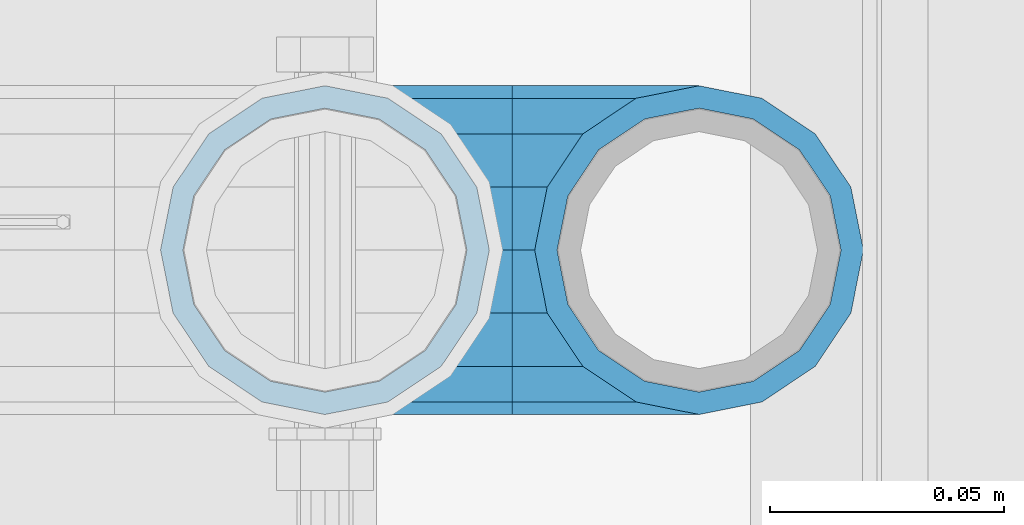
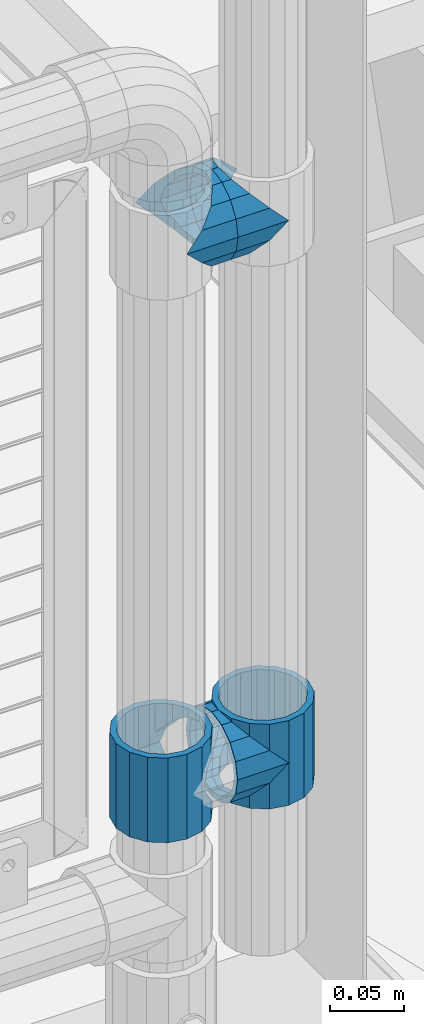
# One storey, part 187 of 270: 5 beams.
"""IFC2X3 building model written with IfcOpenShell, lengths in millimetres."""

from ifc_helpers import new_model, si_unit, frame, origin_with_axes, place, context, subcontext, project, spatial, faceted_brep, material, type_object, element, save


model = new_model("IFC2X3")

# Units and contexts
model_context = context("Model", 3, precision=1e-05, world=origin_with_axes())
body_context = subcontext(model_context, "Body", "Model", "MODEL_VIEW")
ifc_project = project(units=[si_unit("LENGTHUNIT", "METRE", prefix="MILLI"), si_unit("AREAUNIT", "SQUARE_METRE"), si_unit("VOLUMEUNIT", "CUBIC_METRE"), si_unit("MASSUNIT", "GRAM", prefix="KILO"), si_unit("TIMEUNIT", "SECOND"), si_unit("PLANEANGLEUNIT", "RADIAN"), si_unit("SOLIDANGLEUNIT", "STERADIAN"), si_unit("THERMODYNAMICTEMPERATUREUNIT", "DEGREE_CELSIUS"), si_unit("LUMINOUSINTENSITYUNIT", "LUMEN")], contexts=[model_context])

# Site, building, storey
site_placement = place(None, origin_with_axes())
site = spatial("IfcSite", under=ifc_project, at=site_placement, CompositionType="ELEMENT")
building_placement = place(site_placement, origin_with_axes())
building = spatial("IfcBuilding", under=site, at=building_placement, Name="Standard", CompositionType="ELEMENT")
storey_placement = place(building_placement, origin_with_axes())
storey = spatial("IfcBuildingStorey", under=building, at=storey_placement, Name="Undefined", CompositionType="ELEMENT", Elevation=0.0)

# Beams
ifc_material = material(Name="Misc_Undefined")
beam_type = type_object("IfcBeamType", PredefinedType="NOTDEFINED")
beam_1_placement = place(storey_placement, frame((19874.0, -16335.5, 398.670000000001), z_axis=(0.0, 1.0, 0.0), x_axis=(-1.0, 0.0, 0.0)))
element("IfcBeam", 1, at=beam_1_placement, inside=storey, type_object=beam_type, material=ifc_material, context=body_context, shape_type="Brep", body=[
    faceted_brep([(0.0, 0.0, -35.1499999999996), (13.4513226476338, -13.4513226476329, -32.4743655677721), (13.4513226476338, 13.4513226476329, -32.4743655677721), (32.4743655677703, -26.8123795176775, 13.4513226476338), (32.4743655677703, -32.4743655677717, 13.4513226476338), (24.8548033587067, -24.8548033587072, 24.8548033587067), (24.8548033587067, -16.3810424080045, 24.8548033587067), (27.1226768591041, -21.4606908090117, 21.4606908090118), (35.1500000000015, -30.35, 0.0), (35.1500000000015, -35.15, 0.0), (32.8397438117208, -28.0397438117175, 11.6144421722802), (32.8397438117172, -28.0397438117175, -11.6144421722802), (32.4743655677703, -26.8123795176776, -13.4513226476338), (32.4743655677703, -32.4743655677717, -13.4513226476338), (27.1226768591041, -21.4606908090117, -21.4606908090118), (24.8548033587067, -16.3810424080045, -24.8548033587067), (24.8548033587067, -24.8548033587072, -24.8548033587067), (20.0882031229849, -11.6144421722805, -28.0397438117179), (16.6306603983721, 0.0, -30.3500000000004), (20.0882031229849, 11.6144421722805, -28.0397438117179), (24.8548033587067, 16.3810424080045, -24.8548033587067), (24.8548033587067, 24.8548033587072, -24.8548033587067), (27.1226768591041, 21.4606908090117, -21.4606908090118), (32.4743655677703, 26.8123795176775, -13.4513226476338), (32.4743655677703, 32.4743655677717, -13.4513226476338), (32.8397438117172, 28.0397438117175, -11.6144421722802), (35.1500000000015, 30.35, 0.0), (35.1500000000015, 35.1500000000003, 0.0), (32.8397438117208, 28.0397438117175, 11.6144421722802), (32.4743655677703, 26.8123795176776, 13.4513226476338), (32.4743655677703, 32.4743655677717, 13.4513226476338), (27.1226768591041, 21.4606908090117, 21.4606908090118), (24.8548033587067, 16.3810424080045, 24.8548033587067), (24.8548033587067, 24.8548033587072, 24.8548033587067), (13.4513226476338, 13.4513226476329, 32.4743655677721), (13.4513226476338, -13.4513226476329, 32.4743655677721), (0.0, 0.0, 35.1499999999996), (20.0882031229812, 11.6144421722805, 28.0397438117179), (16.6306603983612, 0.0, 30.3500000000004), (20.0882031229812, -11.6144421722805, 28.0397438117179), (40.1500000000015, -35.15, 0.0), (40.1500000000015, -32.4743655677717, 13.4513226476338), (40.1500000000015, -24.8548033587072, 24.8548033587067), (40.1500000000015, -13.4513226476329, 32.4743655677721), (40.1500000000015, 0.0, 35.1499999999996), (40.1500000000015, -24.8548033587072, -24.8548033587067), (40.1500000000015, -32.4743655677717, -13.4513226476338), (40.1500000000015, -13.4513226476329, -32.4743655677721), (40.1500000000015, 0.0, -35.1499999999996), (40.1500000000015, 13.4513226476329, -32.4743655677721), (40.1500000000015, 24.8548033587072, -24.8548033587067), (40.1500000000015, 32.4743655677717, -13.4513226476338), (40.1500000000015, 35.15, 0.0), (40.1500000000015, 32.4743655677717, 13.4513226476338), (40.1500000000015, 24.8548033587072, 24.8548033587067), (40.1500000000015, 13.4513226476329, 32.4743655677721), (40.1500000000015, -21.4606908090117, 21.4606908090118), (40.1500000000015, -11.6144421722805, 28.0397438117179), (40.1500000000015, 0.0, 30.3500000000004), (40.1500000000015, 11.6144421722805, 28.0397438117179), (40.1500000000015, 21.4606908090117, 21.4606908090118), (40.1500000000015, 28.0397438117175, 11.6144421722802), (40.1500000000015, 30.35, 0.0), (40.1500000000015, 28.0397438117175, -11.6144421722802), (40.1500000000015, 21.4606908090117, -21.4606908090118), (40.1500000000015, 11.6144421722805, -28.0397438117179), (40.1500000000015, 0.0, -30.3500000000004), (40.1500000000015, -11.6144421722805, -28.0397438117179), (40.1500000000015, -21.4606908090117, -21.4606908090118), (40.1500000000015, -28.0397438117175, -11.6144421722802), (40.1500000000015, -30.35, 0.0), (40.1500000000015, -28.0397438117175, 11.6144421722802)], [[[0, 1, 2]], [[3, 4, 5, 6, 7]], [[8, 9, 4, 3, 10]], [[11, 12, 13, 9, 8]], [[14, 15, 16, 13, 12]], [[2, 1, 16, 15, 17, 18, 19, 20, 21]], [[21, 20, 22, 23, 24]], [[24, 23, 25, 26, 27]], [[27, 26, 28, 29, 30]], [[30, 29, 31, 32, 33]], [[34, 35, 36]], [[33, 32, 37, 38, 39, 6, 5, 35, 34]], [[40, 41, 4, 9]], [[41, 42, 5, 4]], [[42, 43, 35, 5]], [[43, 44, 36, 35]], [[45, 46, 13, 16]], [[47, 45, 16, 1]], [[48, 47, 1, 0]], [[49, 48, 0, 2]], [[50, 49, 2, 21]], [[51, 50, 21, 24]], [[52, 51, 24, 27]], [[53, 52, 27, 30]], [[54, 53, 30, 33]], [[55, 54, 33, 34]], [[44, 55, 34, 36]], [[46, 40, 9, 13]], [[45, 47, 48, 49, 50, 51, 52, 53, 54, 55, 44, 43, 42, 41, 40, 46], [56, 57, 58, 59, 60, 61, 62, 63, 64, 65, 66, 67, 68, 69, 70, 71]], [[59, 58, 38, 37]], [[60, 59, 37, 32, 31]], [[61, 60, 31, 29, 28]], [[62, 61, 28, 26]], [[63, 62, 26, 25]], [[22, 64, 63, 25, 23]], [[19, 65, 64, 22, 20]], [[66, 65, 19, 18]], [[67, 66, 18, 17]], [[68, 67, 17, 15, 14]], [[69, 68, 14, 12, 11]], [[70, 69, 11, 8]], [[71, 70, 8, 10]], [[7, 56, 71, 10, 3]], [[39, 57, 56, 7, 6]], [[58, 57, 39, 38]]]),
])
beam_2_placement = place(storey_placement, frame((19794.0, -16335.5, 433.82), z_axis=(-1.0, 0.0, 0.0), x_axis=(0.0, 0.0, -1.0)))
element("IfcBeam", 2, at=beam_2_placement, inside=storey, type_object=beam_type, material=ifc_material, context=body_context, shape_type="Brep", body=[
    faceted_brep([(7.11025618828319, -11.6144421722802, -32.8397438117172), (7.11025618828319, -11.6144421722802, -28.0397438117179), (13.689309190989, -21.4606908090118, -21.46069080901), (13.689309190989, -21.4606908090118, -27.1226768591041), (8.33762048232484, -13.4513226476338, -32.4743655677703), (23.5355578277203, -28.0397438117179, -11.614442172282), (23.5355578277203, -28.0397438117179, -20.0882031229885), (18.7689575919954, -24.8548033587067, -24.8548033587067), (35.1500000000015, -30.35, 0.0), (35.1500000000008, -30.3500000000004, -16.6306603983721), (46.7644421722812, -28.0397438117179, -11.614442172282), (46.7644421722812, -28.0397438117179, -20.0882031229885), (51.5310424080071, -24.8548033587067, -24.8548033587067), (56.6106908090125, -21.4606908090118, -21.46069080901), (56.6106908090125, -21.4606908090118, -27.1226768591041), (61.9623795176767, -13.4513226476338, -32.4743655677703), (63.1897438117183, -11.6144421722802, -28.0397438117179), (63.1897438117183, -11.6144421722802, -32.8397438117172), (65.5000000000008, 0.0, -30.3499999999985), (65.5000000000008, 0.0, -35.1500000000015), (63.1897438117183, 11.6144421722802, -28.0397438117179), (63.1897438117183, 11.6144421722802, -32.8397438117208), (56.6106908090125, 21.4606908090118, -21.46069080901), (56.6106908090125, 21.4606908090118, -27.1226768591005), (61.9623795176767, 13.4513226476338, -32.4743655677703), (46.7644421722812, 28.0397438117179, -11.614442172282), (46.7644421722812, 28.0397438117179, -20.0882031229812), (51.5310424080071, 24.8548033587067, -24.8548033587067), (35.1500000000015, 30.35, 0.0), (35.1500000000008, 30.3500000000004, -16.6306603983612), (23.5355578277203, 28.0397438117179, -11.614442172282), (23.5355578277203, 28.0397438117179, -20.0882031229812), (18.7689575919954, 24.8548033587067, -24.8548033587067), (13.689309190989, 21.4606908090118, -21.46069080901), (13.689309190989, 21.4606908090118, -27.1226768591005), (8.33762048232484, 13.4513226476338, -32.4743655677703), (7.11025618828324, 11.6144421722802, -28.0397438117179), (7.11025618828324, 11.6144421722802, -32.8397438117208), (4.80000000000075, 0.0, -30.3499999999985), (4.80000000000075, 0.0, -35.1500000000015), (0.0, 21.4606908090118, 21.46069080901), (0.0, 28.0397438117179, 11.614442172282), (70.2999999999993, 28.0397438117179, 11.614442172282), (70.2999999999993, 21.4606908090118, 21.46069080901), (0.0, 11.6144421722802, 28.0397438117179), (70.2999999999993, 11.6144421722802, 28.0397438117179), (0.0, 0.0, 30.3499999999985), (70.2999999999993, 0.0, 30.3499999999985), (0.0, -11.6144421722802, 28.0397438117179), (70.2999999999993, -11.6144421722802, 28.0397438117179), (0.0, -21.4606908090118, 21.46069080901), (70.2999999999993, -21.4606908090118, 21.46069080901), (0.0, -28.0397438117179, 11.614442172282), (70.2999999999993, -28.0397438117179, 11.614442172282), (0.0, -24.8548033587067, -24.8548033587067), (0.0, -13.4513226476338, -32.4743655677703), (0.0, 0.0, -35.1499999999996), (0.0, -32.4743655677721, 13.4513226476338), (0.0, -35.1499999999996, 0.0), (70.2999999999993, -35.1499999999996, 0.0), (70.2999999999993, -32.4743655677721, 13.4513226476338), (0.0, -24.8548033587067, 24.8548033587067), (70.2999999999993, -24.8548033587067, 24.8548033587067), (0.0, -13.4513226476338, 32.4743655677703), (70.2999999999993, -13.4513226476338, 32.4743655677703), (0.0, 0.0, 35.1499999999996), (70.2999999999993, 0.0, 35.1500000000015), (0.0, 13.4513226476338, 32.4743655677703), (70.2999999999993, 13.4513226476338, 32.4743655677703), (0.0, 24.8548033587067, 24.8548033587067), (70.2999999999993, 24.8548033587067, 24.8548033587067), (0.0, 32.4743655677721, 13.4513226476338), (70.2999999999993, 32.4743655677721, 13.4513226476338), (0.0, 35.1499999999996, 0.0), (70.2999999999993, 35.1499999999996, 0.0), (0.0, 32.4743655677721, -13.4513226476338), (70.2999999999993, 32.4743655677721, -13.4513226476338), (70.2999999999993, -13.4513226476338, -32.4743655677703), (70.2999999999993, -24.8548033587067, -24.8548033587067), (70.2999999999993, 0.0, -35.1500000000015), (70.2999999999993, 13.4513226476338, -32.4743655677703), (70.2999999999993, 24.8548033587067, -24.8548033587067), (0.0, 24.8548033587067, -24.8548033587067), (0.0, 13.4513226476338, -32.4743655677703), (70.2999999999993, -32.4743655677721, -13.4513226476338), (0.0, -32.4743655677721, -13.4513226476338), (0.0, -28.0397438117179, -11.614442172282), (0.0, -21.4606908090118, -21.46069080901), (0.0, -11.6144421722802, -28.0397438117179), (0.0, 0.0, -30.3499999999985), (0.0, 11.6144421722802, -28.0397438117179), (0.0, 21.4606908090118, -21.46069080901), (0.0, 28.0397438117179, -11.614442172282), (0.0, 30.3500000000004, 0.0), (0.0, -30.3500000000004, 0.0), (70.2999999999993, 30.3500000000004, 0.0), (70.2999999999993, 28.0397438117179, -11.614442172282), (70.2999999999993, 21.4606908090118, -21.46069080901), (70.2999999999993, 11.6144421722802, -28.0397438117179), (70.2999999999993, 0.0, -30.3499999999985), (70.2999999999993, -11.6144421722802, -28.0397438117179), (70.2999999999993, -21.4606908090118, -21.46069080901), (70.2999999999993, -28.0397438117179, -11.614442172282), (70.2999999999993, -30.3500000000004, 0.0)], [[[0, 1, 2, 3, 4]], [[3, 2, 5, 6, 7]], [[6, 5, 8, 9]], [[9, 8, 10, 11]], [[12, 11, 10, 13, 14]], [[15, 14, 13, 16, 17]], [[17, 16, 18, 19]], [[19, 18, 20, 21]], [[21, 20, 22, 23, 24]], [[23, 22, 25, 26, 27]], [[26, 25, 28, 29]], [[29, 28, 30, 31]], [[32, 31, 30, 33, 34]], [[35, 34, 33, 36, 37]], [[37, 36, 38, 39]], [[39, 38, 1, 0]], [[40, 41, 42, 43]], [[44, 40, 43, 45]], [[46, 44, 45, 47]], [[48, 46, 47, 49]], [[50, 48, 49, 51]], [[52, 50, 51, 53]], [[7, 54, 55, 4, 3]], [[4, 55, 56, 39, 0]], [[57, 58, 59, 60]], [[61, 57, 60, 62]], [[63, 61, 62, 64]], [[65, 63, 64, 66]], [[67, 65, 66, 68]], [[69, 67, 68, 70]], [[71, 69, 70, 72]], [[73, 71, 72, 74]], [[75, 73, 74, 76]], [[77, 78, 12, 14, 15]], [[79, 77, 15, 17, 19]], [[24, 80, 79, 19, 21]], [[27, 81, 80, 24, 23]], [[82, 75, 76, 81, 27, 26, 29, 31, 32]], [[83, 82, 32, 34, 35]], [[56, 83, 35, 37, 39]], [[9, 11, 12, 78, 84, 85, 54, 7, 6]], [[58, 85, 84, 59]], [[57, 61, 63, 65, 67, 69, 71, 73, 75, 82, 83, 56, 55, 54, 85, 58], [86, 87, 88, 89, 90, 91, 92, 93, 41, 40, 44, 46, 48, 50, 52, 94]], [[90, 89, 38, 36]], [[91, 90, 36, 33]], [[92, 91, 33, 30]], [[93, 92, 30, 28]], [[41, 93, 28, 95, 42]], [[96, 95, 28, 25]], [[97, 96, 25, 22]], [[98, 97, 22, 20]], [[99, 98, 20, 18]], [[100, 99, 18, 16]], [[101, 100, 16, 13]], [[102, 101, 13, 10]], [[103, 102, 10, 8]], [[78, 77, 79, 80, 81, 76, 74, 72, 70, 68, 66, 64, 62, 60, 59, 84], [51, 49, 47, 45, 43, 42, 95, 96, 97, 98, 99, 100, 101, 102, 103, 53]], [[8, 94, 52, 53, 103]], [[86, 94, 8, 5]], [[87, 86, 5, 2]], [[88, 87, 2, 1]], [[89, 88, 1, 38]]]),
])
beam_3_placement = place(storey_placement, frame((19874.0, -16335.5, 433.82), z_axis=(1.0, 0.0, 0.0), x_axis=(0.0, 0.0, -1.0)))
element("IfcBeam", 3, at=beam_3_placement, inside=storey, type_object=beam_type, material=ifc_material, context=body_context, shape_type="Brep", body=[
    faceted_brep([(56.6106908090125, 21.4606908090118, -27.1226768591005), (56.6106908090125, 21.4606908090118, -21.46069080901), (46.7644421722812, 28.0397438117179, -11.614442172282), (46.7644421722812, 28.0397438117179, -20.0882031229812), (51.5310424080071, 24.8548033587067, -24.8548033587067), (63.1897438117183, 11.6144421722802, -32.8397438117208), (63.1897438117183, 11.6144421722802, -28.0397438117179), (61.9623795176767, 13.4513226476338, -32.4743655677703), (65.5000000000008, 0.0, -35.1500000000015), (65.5000000000008, 0.0, -30.3499999999985), (63.1897438117183, -11.6144421722802, -32.8397438117172), (63.1897438117183, -11.6144421722802, -28.0397438117179), (61.9623795176767, -13.4513226476338, -32.4743655677703), (56.6106908090125, -21.4606908090118, -27.1226768591041), (56.6106908090125, -21.4606908090118, -21.46069080901), (51.5310424080071, -24.8548033587067, -24.8548033587067), (46.7644421722812, -28.0397438117179, -20.0882031229885), (46.7644421722812, -28.0397438117179, -11.614442172282), (35.1500000000008, -30.3500000000004, -16.6306603983721), (35.1500000000015, -30.35, 0.0), (23.5355578277203, -28.0397438117179, -20.0882031229885), (23.5355578277203, -28.0397438117179, -11.614442172282), (13.689309190989, -21.4606908090118, -27.1226768591041), (13.689309190989, -21.4606908090118, -21.46069080901), (18.7689575919954, -24.8548033587067, -24.8548033587067), (7.11025618828319, -11.6144421722802, -32.8397438117172), (7.11025618828319, -11.6144421722802, -28.0397438117179), (8.33762048232484, -13.4513226476338, -32.4743655677703), (4.80000000000075, 0.0, -35.1500000000015), (4.80000000000075, 0.0, -30.3499999999985), (7.11025618828324, 11.6144421722802, -32.8397438117208), (7.11025618828324, 11.6144421722802, -28.0397438117179), (8.33762048232484, 13.4513226476338, -32.4743655677703), (13.689309190989, 21.4606908090118, -27.1226768591005), (13.689309190989, 21.4606908090118, -21.46069080901), (18.7689575919954, 24.8548033587067, -24.8548033587067), (23.5355578277203, 28.0397438117179, -20.0882031229812), (23.5355578277203, 28.0397438117179, -11.614442172282), (35.1500000000008, 30.3500000000004, -16.6306603983612), (35.1500000000015, 30.35, 0.0), (0.0, 32.4743655677721, -13.4513226476338), (0.0, 35.1499999999996, 0.0), (70.2999999999993, 35.1499999999996, 0.0), (70.2999999999993, 32.4743655677721, -13.4513226476338), (0.0, 32.4743655677721, 13.4513226476338), (70.2999999999993, 32.4743655677721, 13.4513226476338), (0.0, 24.8548033587067, 24.8548033587067), (70.2999999999993, 24.8548033587067, 24.8548033587067), (0.0, 13.4513226476338, 32.4743655677703), (70.2999999999993, 13.4513226476338, 32.4743655677703), (0.0, 0.0, 35.1499999999996), (70.2999999999993, 0.0, 35.1500000000015), (0.0, -13.4513226476338, 32.4743655677703), (70.2999999999993, -13.4513226476338, 32.4743655677703), (0.0, -24.8548033587067, 24.8548033587067), (70.2999999999993, -24.8548033587067, 24.8548033587067), (0.0, -32.4743655677721, 13.4513226476338), (70.2999999999993, -32.4743655677721, 13.4513226476338), (0.0, -35.1499999999996, 0.0), (70.2999999999993, -35.1499999999996, 0.0), (70.2999999999993, -30.3500000000004, 0.0), (70.2999999999993, -28.0397438117179, -11.614442172282), (70.2999999999993, -21.4606908090118, -21.46069080901), (70.2999999999993, -11.6144421722802, -28.0397438117179), (70.2999999999993, 0.0, -30.3499999999985), (70.2999999999993, 11.6144421722802, -28.0397438117179), (70.2999999999993, 21.4606908090118, -21.46069080901), (70.2999999999993, 28.0397438117179, -11.614442172282), (0.0, -28.0397438117179, -11.614442172282), (0.0, -30.3500000000004, 0.0), (0.0, -21.4606908090118, -21.46069080901), (0.0, -11.6144421722802, -28.0397438117179), (0.0, 0.0, -30.3499999999985), (0.0, 11.6144421722802, -28.0397438117179), (0.0, 21.4606908090118, -21.46069080901), (0.0, 28.0397438117179, -11.614442172282), (0.0, 30.3500000000004, 0.0), (70.2999999999993, 30.3500000000004, 0.0), (0.0, 28.0397438117179, 11.614442172282), (70.2999999999993, 28.0397438117179, 11.614442172282), (0.0, 21.4606908090118, 21.46069080901), (70.2999999999993, 21.4606908090118, 21.46069080901), (0.0, 11.6144421722802, 28.0397438117179), (70.2999999999993, 11.6144421722802, 28.0397438117179), (0.0, 0.0, 30.3499999999985), (70.2999999999993, 0.0, 30.3499999999985), (0.0, -11.6144421722802, 28.0397438117179), (70.2999999999993, -11.6144421722802, 28.0397438117179), (0.0, -21.4606908090118, 21.46069080901), (70.2999999999993, -21.4606908090118, 21.46069080901), (0.0, -28.0397438117179, 11.614442172282), (70.2999999999993, -28.0397438117179, 11.614442172282), (70.2999999999993, -24.8548033587067, -24.8548033587067), (70.2999999999993, -13.4513226476338, -32.4743655677703), (70.2999999999993, 0.0, -35.1500000000015), (70.2999999999993, 13.4513226476338, -32.4743655677703), (70.2999999999993, 24.8548033587067, -24.8548033587067), (70.2999999999993, -32.4743655677721, -13.4513226476338), (0.0, -32.4743655677721, -13.4513226476338), (0.0, 24.8548033587067, -24.8548033587067), (0.0, 13.4513226476338, -32.4743655677703), (0.0, 0.0, -35.1499999999996), (0.0, -13.4513226476338, -32.4743655677703), (0.0, -24.8548033587067, -24.8548033587067)], [[[0, 1, 2, 3, 4]], [[5, 6, 1, 0, 7]], [[8, 9, 6, 5]], [[10, 11, 9, 8]], [[12, 13, 14, 11, 10]], [[15, 16, 17, 14, 13]], [[18, 19, 17, 16]], [[20, 21, 19, 18]], [[22, 23, 21, 20, 24]], [[25, 26, 23, 22, 27]], [[28, 29, 26, 25]], [[30, 31, 29, 28]], [[32, 33, 34, 31, 30]], [[35, 36, 37, 34, 33]], [[38, 39, 37, 36]], [[3, 2, 39, 38]], [[40, 41, 42, 43]], [[41, 44, 45, 42]], [[44, 46, 47, 45]], [[46, 48, 49, 47]], [[48, 50, 51, 49]], [[50, 52, 53, 51]], [[52, 54, 55, 53]], [[54, 56, 57, 55]], [[56, 58, 59, 57]], [[60, 61, 17, 19]], [[61, 62, 14, 17]], [[62, 63, 11, 14]], [[63, 64, 9, 11]], [[64, 65, 6, 9]], [[65, 66, 1, 6]], [[66, 67, 2, 1]], [[68, 69, 19, 21]], [[70, 68, 21, 23]], [[71, 70, 23, 26]], [[72, 71, 26, 29]], [[73, 72, 29, 31]], [[74, 73, 31, 34]], [[75, 74, 34, 37]], [[76, 75, 37, 39]], [[67, 77, 39, 2]], [[78, 76, 39, 77, 79]], [[80, 78, 79, 81]], [[82, 80, 81, 83]], [[84, 82, 83, 85]], [[86, 84, 85, 87]], [[88, 86, 87, 89]], [[90, 88, 89, 91]], [[19, 69, 90, 91, 60]], [[92, 93, 94, 95, 96, 43, 42, 45, 47, 49, 51, 53, 55, 57, 59, 97], [89, 87, 85, 83, 81, 79, 77, 67, 66, 65, 64, 63, 62, 61, 60, 91]], [[58, 98, 97, 59]], [[56, 54, 52, 50, 48, 46, 44, 41, 40, 99, 100, 101, 102, 103, 98, 58], [68, 70, 71, 72, 73, 74, 75, 76, 78, 80, 82, 84, 86, 88, 90, 69]], [[100, 99, 35, 33, 32]], [[101, 100, 32, 30, 28]], [[27, 102, 101, 28, 25]], [[24, 103, 102, 27, 22]], [[18, 16, 15, 92, 97, 98, 103, 24, 20]], [[93, 92, 15, 13, 12]], [[94, 93, 12, 10, 8]], [[7, 95, 94, 8, 5]], [[4, 96, 95, 7, 0]], [[99, 40, 43, 96, 4, 3, 38, 36, 35]]]),
])
beam_4_placement = place(storey_placement, frame((19794.0, -16335.5, 848.670000000001), z_axis=(0.0, -1.0, 0.0), x_axis=(1.0, 0.0, 0.0)))
element("IfcBeam", 4, at=beam_4_placement, inside=storey, type_object=beam_type, material=ifc_material, context=body_context, shape_type="Brep", body=[
    faceted_brep([(0.0, 0.0, -35.1499999999996), (13.4513226476338, -13.4513226476329, -32.4743655677721), (13.4513226476338, 13.4513226476329, -32.4743655677721), (32.4743655677703, 32.4743655677717, 13.4513226476338), (32.4743655677703, 26.8123795176776, 13.4513226476338), (27.1226768591041, 21.4606908090117, 21.4606908090118), (24.8548033587067, 16.3810424080045, 24.8548033587067), (24.8548033587067, 24.8548033587072, 24.8548033587067), (13.4513226476338, 13.4513226476329, 32.4743655677721), (13.4513226476338, -13.4513226476329, 32.4743655677721), (0.0, 0.0, 35.1499999999996), (20.0882031229812, 11.6144421722805, 28.0397438117179), (16.6306603983612, 0.0, 30.3500000000004), (20.0882031229812, -11.6144421722805, 28.0397438117179), (24.8548033587067, -16.3810424080045, 24.8548033587067), (24.8548033587067, -24.8548033587072, 24.8548033587067), (32.4743655677703, -26.8123795176775, 13.4513226476338), (32.4743655677703, -32.4743655677717, 13.4513226476338), (27.1226768591041, -21.4606908090117, 21.4606908090118), (35.1500000000015, -30.35, 0.0), (35.1500000000015, -35.15, 0.0), (32.8397438117208, -28.0397438117175, 11.6144421722802), (32.8397438117172, -28.0397438117175, -11.6144421722802), (32.4743655677703, -26.8123795176776, -13.4513226476338), (32.4743655677703, -32.4743655677717, -13.4513226476338), (27.1226768591041, -21.4606908090117, -21.4606908090118), (24.8548033587067, -16.3810424080045, -24.8548033587067), (24.8548033587067, -24.8548033587072, -24.8548033587067), (20.0882031229849, -11.6144421722805, -28.0397438117179), (16.6306603983721, 0.0, -30.3500000000004), (20.0882031229849, 11.6144421722805, -28.0397438117179), (24.8548033587067, 16.3810424080045, -24.8548033587067), (24.8548033587067, 24.8548033587072, -24.8548033587067), (27.1226768591041, 21.4606908090117, -21.4606908090118), (32.4743655677703, 26.8123795176775, -13.4513226476338), (32.4743655677703, 32.4743655677717, -13.4513226476338), (32.8397438117172, 28.0397438117175, -11.6144421722802), (35.1500000000015, 30.35, 0.0), (35.1500000000015, 35.1500000000003, 0.0), (32.8397438117208, 28.0397438117175, 11.6144421722802), (40.1500000000015, -35.15, 0.0), (40.1500000000015, -32.4743655677717, 13.4513226476338), (40.1500000000015, -24.8548033587072, 24.8548033587067), (40.1500000000015, -13.4513226476329, 32.4743655677721), (40.1500000000015, 0.0, 35.1499999999996), (40.1500000000015, 13.4513226476329, 32.4743655677721), (40.1500000000015, 24.8548033587072, 24.8548033587067), (40.1500000000015, 32.4743655677717, 13.4513226476338), (40.1500000000015, 35.15, 0.0), (40.1500000000015, -24.8548033587072, -24.8548033587067), (40.1500000000015, -32.4743655677717, -13.4513226476338), (40.1500000000015, -13.4513226476329, -32.4743655677721), (40.1500000000015, 0.0, -35.1499999999996), (40.1500000000015, 13.4513226476329, -32.4743655677721), (40.1500000000015, 24.8548033587072, -24.8548033587067), (40.1500000000015, 32.4743655677717, -13.4513226476338), (40.1500000000015, -21.4606908090117, 21.4606908090118), (40.1500000000015, -11.6144421722805, 28.0397438117179), (40.1500000000015, 0.0, 30.3500000000004), (40.1500000000015, 11.6144421722805, 28.0397438117179), (40.1500000000015, 21.4606908090117, 21.4606908090118), (40.1500000000015, 28.0397438117175, 11.6144421722802), (40.1500000000015, 30.35, 0.0), (40.1500000000015, 28.0397438117175, -11.6144421722802), (40.1500000000015, 21.4606908090117, -21.4606908090118), (40.1500000000015, 11.6144421722805, -28.0397438117179), (40.1500000000015, 0.0, -30.3500000000004), (40.1500000000015, -11.6144421722805, -28.0397438117179), (40.1500000000015, -21.4606908090117, -21.4606908090118), (40.1500000000015, -28.0397438117175, -11.6144421722802), (40.1500000000015, -30.35, 0.0), (40.1500000000015, -28.0397438117175, 11.6144421722802)], [[[0, 1, 2]], [[3, 4, 5, 6, 7]], [[8, 9, 10]], [[7, 6, 11, 12, 13, 14, 15, 9, 8]], [[16, 17, 15, 14, 18]], [[19, 20, 17, 16, 21]], [[22, 23, 24, 20, 19]], [[25, 26, 27, 24, 23]], [[2, 1, 27, 26, 28, 29, 30, 31, 32]], [[32, 31, 33, 34, 35]], [[35, 34, 36, 37, 38]], [[38, 37, 39, 4, 3]], [[40, 41, 17, 20]], [[41, 42, 15, 17]], [[42, 43, 9, 15]], [[43, 44, 10, 9]], [[44, 45, 8, 10]], [[45, 46, 7, 8]], [[46, 47, 3, 7]], [[47, 48, 38, 3]], [[49, 50, 24, 27]], [[51, 49, 27, 1]], [[52, 51, 1, 0]], [[53, 52, 0, 2]], [[54, 53, 2, 32]], [[55, 54, 32, 35]], [[48, 55, 35, 38]], [[50, 40, 20, 24]], [[49, 51, 52, 53, 54, 55, 48, 47, 46, 45, 44, 43, 42, 41, 40, 50], [56, 57, 58, 59, 60, 61, 62, 63, 64, 65, 66, 67, 68, 69, 70, 71]], [[63, 62, 37, 36]], [[33, 64, 63, 36, 34]], [[30, 65, 64, 33, 31]], [[66, 65, 30, 29]], [[67, 66, 29, 28]], [[68, 67, 28, 26, 25]], [[69, 68, 25, 23, 22]], [[70, 69, 22, 19]], [[71, 70, 19, 21]], [[18, 56, 71, 21, 16]], [[13, 57, 56, 18, 14]], [[58, 57, 13, 12]], [[59, 58, 12, 11]], [[60, 59, 11, 6, 5]], [[61, 60, 5, 4, 39]], [[62, 61, 39, 37]]]),
])
beam_5_placement = place(storey_placement, frame((19874.0, -16335.5, 848.670000000001), z_axis=(0.0, 1.0, 0.0), x_axis=(-1.0, 0.0, 0.0)))
element("IfcBeam", 5, at=beam_5_placement, inside=storey, type_object=beam_type, material=ifc_material, context=body_context, shape_type="Brep", body=[
    faceted_brep([(0.0, 0.0, -35.1499999999996), (13.4513226476338, -13.4513226476329, -32.4743655677721), (13.4513226476338, 13.4513226476329, -32.4743655677721), (32.4743655677703, -26.8123795176775, 13.4513226476338), (32.4743655677703, -32.4743655677717, 13.4513226476338), (24.8548033587067, -24.8548033587072, 24.8548033587067), (24.8548033587067, -16.3810424080045, 24.8548033587067), (27.1226768591041, -21.4606908090117, 21.4606908090118), (35.1500000000015, -30.35, 0.0), (35.1500000000015, -35.15, 0.0), (32.8397438117208, -28.0397438117175, 11.6144421722802), (32.8397438117172, -28.0397438117175, -11.6144421722802), (32.4743655677703, -26.8123795176776, -13.4513226476338), (32.4743655677703, -32.4743655677717, -13.4513226476338), (27.1226768591041, -21.4606908090117, -21.4606908090118), (24.8548033587067, -16.3810424080045, -24.8548033587067), (24.8548033587067, -24.8548033587072, -24.8548033587067), (20.0882031229849, -11.6144421722805, -28.0397438117179), (16.6306603983721, 0.0, -30.3500000000004), (20.0882031229849, 11.6144421722805, -28.0397438117179), (24.8548033587067, 16.3810424080045, -24.8548033587067), (24.8548033587067, 24.8548033587072, -24.8548033587067), (27.1226768591041, 21.4606908090117, -21.4606908090118), (32.4743655677703, 26.8123795176775, -13.4513226476338), (32.4743655677703, 32.4743655677717, -13.4513226476338), (32.8397438117172, 28.0397438117175, -11.6144421722802), (35.1500000000015, 30.35, 0.0), (35.1500000000015, 35.1500000000003, 0.0), (32.8397438117208, 28.0397438117175, 11.6144421722802), (32.4743655677703, 26.8123795176776, 13.4513226476338), (32.4743655677703, 32.4743655677717, 13.4513226476338), (27.1226768591041, 21.4606908090117, 21.4606908090118), (24.8548033587067, 16.3810424080045, 24.8548033587067), (24.8548033587067, 24.8548033587072, 24.8548033587067), (13.4513226476338, 13.4513226476329, 32.4743655677721), (13.4513226476338, -13.4513226476329, 32.4743655677721), (0.0, 0.0, 35.1499999999996), (20.0882031229812, 11.6144421722805, 28.0397438117179), (16.6306603983612, 0.0, 30.3500000000004), (20.0882031229812, -11.6144421722805, 28.0397438117179), (40.1500000000015, -35.15, 0.0), (40.1500000000015, -32.4743655677717, 13.4513226476338), (40.1500000000015, -24.8548033587072, 24.8548033587067), (40.1500000000015, -13.4513226476329, 32.4743655677721), (40.1500000000015, 0.0, 35.1499999999996), (40.1500000000015, -24.8548033587072, -24.8548033587067), (40.1500000000015, -32.4743655677717, -13.4513226476338), (40.1500000000015, -13.4513226476329, -32.4743655677721), (40.1500000000015, 0.0, -35.1499999999996), (40.1500000000015, 13.4513226476329, -32.4743655677721), (40.1500000000015, 24.8548033587072, -24.8548033587067), (40.1500000000015, 32.4743655677717, -13.4513226476338), (40.1500000000015, 35.15, 0.0), (40.1500000000015, 32.4743655677717, 13.4513226476338), (40.1500000000015, 24.8548033587072, 24.8548033587067), (40.1500000000015, 13.4513226476329, 32.4743655677721), (40.1500000000015, -21.4606908090117, 21.4606908090118), (40.1500000000015, -11.6144421722805, 28.0397438117179), (40.1500000000015, 0.0, 30.3500000000004), (40.1500000000015, 11.6144421722805, 28.0397438117179), (40.1500000000015, 21.4606908090117, 21.4606908090118), (40.1500000000015, 28.0397438117175, 11.6144421722802), (40.1500000000015, 30.35, 0.0), (40.1500000000015, 28.0397438117175, -11.6144421722802), (40.1500000000015, 21.4606908090117, -21.4606908090118), (40.1500000000015, 11.6144421722805, -28.0397438117179), (40.1500000000015, 0.0, -30.3500000000004), (40.1500000000015, -11.6144421722805, -28.0397438117179), (40.1500000000015, -21.4606908090117, -21.4606908090118), (40.1500000000015, -28.0397438117175, -11.6144421722802), (40.1500000000015, -30.35, 0.0), (40.1500000000015, -28.0397438117175, 11.6144421722802)], [[[0, 1, 2]], [[3, 4, 5, 6, 7]], [[8, 9, 4, 3, 10]], [[11, 12, 13, 9, 8]], [[14, 15, 16, 13, 12]], [[2, 1, 16, 15, 17, 18, 19, 20, 21]], [[21, 20, 22, 23, 24]], [[24, 23, 25, 26, 27]], [[27, 26, 28, 29, 30]], [[30, 29, 31, 32, 33]], [[34, 35, 36]], [[33, 32, 37, 38, 39, 6, 5, 35, 34]], [[40, 41, 4, 9]], [[41, 42, 5, 4]], [[42, 43, 35, 5]], [[43, 44, 36, 35]], [[45, 46, 13, 16]], [[47, 45, 16, 1]], [[48, 47, 1, 0]], [[49, 48, 0, 2]], [[50, 49, 2, 21]], [[51, 50, 21, 24]], [[52, 51, 24, 27]], [[53, 52, 27, 30]], [[54, 53, 30, 33]], [[55, 54, 33, 34]], [[44, 55, 34, 36]], [[46, 40, 9, 13]], [[45, 47, 48, 49, 50, 51, 52, 53, 54, 55, 44, 43, 42, 41, 40, 46], [56, 57, 58, 59, 60, 61, 62, 63, 64, 65, 66, 67, 68, 69, 70, 71]], [[59, 58, 38, 37]], [[60, 59, 37, 32, 31]], [[61, 60, 31, 29, 28]], [[62, 61, 28, 26]], [[63, 62, 26, 25]], [[22, 64, 63, 25, 23]], [[19, 65, 64, 22, 20]], [[66, 65, 19, 18]], [[67, 66, 18, 17]], [[68, 67, 17, 15, 14]], [[69, 68, 14, 12, 11]], [[70, 69, 11, 8]], [[71, 70, 8, 10]], [[7, 56, 71, 10, 3]], [[39, 57, 56, 7, 6]], [[58, 57, 39, 38]]]),
])

save(model, "model.ifc")
